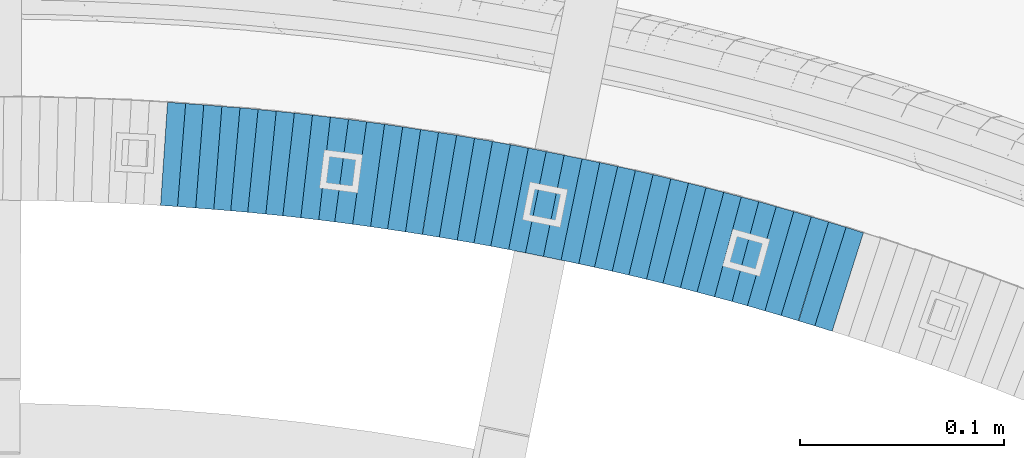
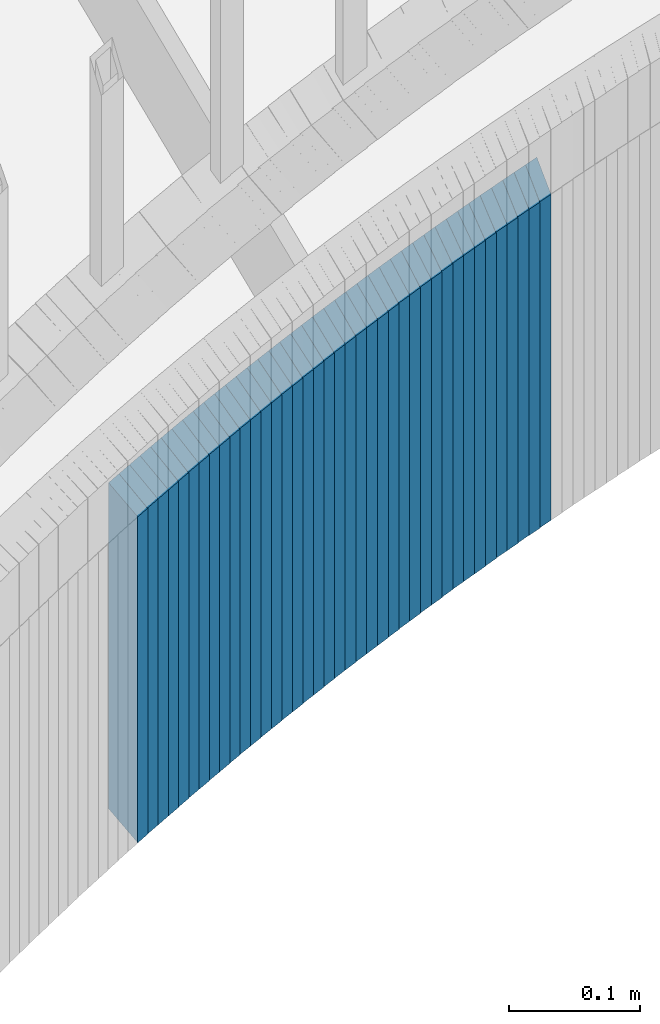
# One storey, part 901 of 975: 39 plates.
"""IFC2X3 building model written with IfcOpenShell, lengths in millimetres."""

from ifc_helpers import new_model, si_unit, frame, origin_with_axes, place, context, subcontext, project, spatial, faceted_brep, material, type_object, element, save


model = new_model("IFC2X3")

# Units and contexts
model_context = context("Model", 3, precision=1e-05, world=origin_with_axes())
body_context = subcontext(model_context, "Body", "Model", "MODEL_VIEW")
ifc_project = project(units=[si_unit("LENGTHUNIT", "METRE", prefix="MILLI"), si_unit("AREAUNIT", "SQUARE_METRE"), si_unit("VOLUMEUNIT", "CUBIC_METRE"), si_unit("MASSUNIT", "GRAM", prefix="KILO"), si_unit("TIMEUNIT", "SECOND"), si_unit("PLANEANGLEUNIT", "RADIAN"), si_unit("SOLIDANGLEUNIT", "STERADIAN"), si_unit("THERMODYNAMICTEMPERATUREUNIT", "DEGREE_CELSIUS"), si_unit("LUMINOUSINTENSITYUNIT", "LUMEN")], contexts=[model_context])

# Site, building, storey
site_placement = place(None, origin_with_axes())
site = spatial("IfcSite", under=ifc_project, at=site_placement, CompositionType="ELEMENT")
building_placement = place(site_placement, origin_with_axes())
building = spatial("IfcBuilding", under=site, at=building_placement, Name="Undefined", CompositionType="ELEMENT")
storey_placement = place(building_placement, origin_with_axes())
storey = spatial("IfcBuildingStorey", under=building, at=storey_placement, Name="Undefined", CompositionType="ELEMENT", Elevation=0.0)

# Plates
ifc_material = material(Name="STEEL/A36")
plate_type = type_object("IfcPlateType", PredefinedType="NOTDEFINED")
plate_1_placement = place(storey_placement, frame((35149.4859453928, 4737.7495007336, 1342.10000000059), z_axis=(0.953072925181811, -0.302740812057751, 0.0), x_axis=(0.0, 0.0, -1.0)))
element("IfcPlate", 1, at=plate_1_placement, inside=storey, type_object=plate_type, material=ifc_material, Name="WALL", context=body_context, shape_type="Brep", body=[
    faceted_brep([(0.0, -25.3999999999724, -1.81898940354586e-11), (-5.69999980926514, -25.3999999999724, 8.91964149478372), (-5.69999980926514, 25.400000000016, 8.9196414947528), (0.0, 25.3999999999869, 1.45519152283669e-11), (299.100006103516, -25.3999999999724, 8.91964149478372), (299.100006103516, 25.400000000016, 8.9196414947528), (304.799987792969, -25.3999999999724, -1.81898940354586e-11), (304.799987792969, 25.3999999999869, 1.45519152283669e-11)], [[[0, 1, 2, 3]], [[1, 4, 5, 2]], [[4, 6, 7, 5]], [[6, 0, 3, 7]], [[5, 7, 3, 2]], [[6, 4, 1, 0]]]),
])
plate_2_placement = place(storey_placement, frame((35141.2250686855, 4740.24438277839, 1336.40000000059), z_axis=(0.957211427350146, -0.289389501105857, 0.0), x_axis=(0.0, 0.0, -1.0)))
element("IfcPlate", 2, at=plate_2_placement, inside=storey, type_object=plate_type, material=ifc_material, Name="WALL", context=body_context, shape_type="Brep", body=[
    faceted_brep([(0.0, -25.3999999999724, -1.81898940354586e-11), (-5.69999980926514, -25.3999999999833, 8.98053455353147), (-5.69999980926514, 25.3999999999396, 8.98053455348781), (0.0, 25.3999999999869, 1.45519152283669e-11), (299.100006103516, -25.3999999999833, 8.98053455353147), (299.100006103516, 25.3999999999396, 8.98053455348781), (304.799987792969, -25.3999999999724, -1.81898940354586e-11), (304.799987792969, 25.3999999999869, 1.45519152283669e-11)], [[[0, 1, 2, 3]], [[1, 4, 5, 2]], [[4, 6, 7, 5]], [[6, 0, 3, 7]], [[5, 7, 3, 2]], [[6, 4, 1, 0]]]),
])
plate_3_placement = place(storey_placement, frame((35132.6459517336, 4742.86844248826, 1330.60000000059), z_axis=(0.956264194651992, -0.292504341893548, 0.0), x_axis=(0.0, 0.0, -1.0)))
element("IfcPlate", 3, at=plate_3_placement, inside=storey, type_object=plate_type, material=ifc_material, Name="WALL", context=body_context, shape_type="Brep", body=[
    faceted_brep([(0.0, -25.3999999999724, -1.81898940354586e-11), (-5.80000019073486, -25.3999999999542, 8.88650703432359), (-5.80000019073486, 25.4000000000233, 8.88650703432359), (0.0, 25.3999999999869, 1.45519152283669e-11), (299.0, -25.3999999999542, 8.88650703432359), (299.0, 25.4000000000233, 8.88650703432359), (304.799987792969, -25.3999999999724, -1.81898940354586e-11), (304.799987792969, 25.3999999999869, 1.45519152283669e-11)], [[[0, 1, 2, 3]], [[1, 4, 5, 2]], [[4, 6, 7, 5]], [[6, 0, 3, 7]], [[5, 7, 3, 2]], [[6, 4, 1, 0]]]),
])
for number, where, z_axis, x_axis, name in (
    (4, (35124.3853459953, 4745.26720992587, 1324.90000000059), (0.96024972858431, -0.279142362879158, 0.0), (0.0, 0.0, -1.0), "WALL"),
    (5, (35115.78534599, 4747.76720992593, 1319.20000000059), (0.96024972858431, -0.279142362879158, 0.0), (0.0, 0.0, -1.0), "WALL"),
):
    element("IfcPlate", number, at=place(storey_placement, frame(where, z_axis=z_axis, x_axis=x_axis)), inside=storey, type_object=plate_type, material=ifc_material, Name=name, context=body_context, shape_type="Brep", body=[
        faceted_brep([(0.0, -25.3999999999724, -1.81898940354586e-11), (-5.69999980926514, -25.4000000000087, 8.9643735885511), (-5.69999980926514, 25.4000000000669, 8.96437358860567), (0.0, 25.3999999999869, 1.45519152283669e-11), (299.100006103516, -25.4000000000087, 8.9643735885511), (299.100006103516, 25.4000000000669, 8.96437358860567), (304.799987792969, -25.3999999999724, -1.81898940354586e-11), (304.799987792969, 25.3999999999869, 1.45519152283669e-11)], [[[0, 1, 2, 3]], [[1, 4, 5, 2]], [[4, 6, 7, 5]], [[6, 0, 3, 7]], [[5, 7, 3, 2]], [[6, 4, 1, 0]]]),
    ])
plate_4_placement = place(storey_placement, frame((35107.4480682082, 4750.09236697988, 1313.40000000059), z_axis=(0.963196301261052, -0.268798968072851, 0.0), x_axis=(0.0, 0.0, -1.0)))
element("IfcPlate", 6, at=plate_4_placement, inside=storey, type_object=plate_type, material=ifc_material, Name="WALL", context=body_context, shape_type="Brep", body=[
    faceted_brep([(0.0, -25.3999999999724, -1.81898940354586e-11), (-5.80000019073486, -25.399999999976, 8.9274854660398), (-5.80000019073486, 25.4000000000269, 8.92748546601433), (0.0, 25.3999999999869, 1.45519152283669e-11), (299.0, -25.399999999976, 8.9274854660398), (299.0, 25.4000000000269, 8.92748546601433), (304.799987792969, -25.3999999999724, -1.81898940354586e-11), (304.799987792969, 25.3999999999869, 1.45519152283669e-11)], [[[0, 1, 2, 3]], [[1, 4, 5, 2]], [[4, 6, 7, 5]], [[6, 0, 3, 7]], [[5, 7, 3, 2]], [[6, 4, 1, 0]]]),
])
for number, where, z_axis, x_axis, name in (
    (7, (35099.113173802, 4752.31992761313, 1307.70000000059), (0.966048244824465, -0.258361739953056, 0.0), (0.0, 0.0, -1.0), "WALL"),
    (8, (35090.5131737926, 4754.6199276129, 1302.00000000058), (0.966048244824465, -0.258361739953056, 0.0), (0.0, 0.0, -1.0), "WALL"),
):
    element("IfcPlate", number, at=place(storey_placement, frame(where, z_axis=z_axis, x_axis=x_axis)), inside=storey, type_object=plate_type, material=ifc_material, Name=name, context=body_context, shape_type="Brep", body=[
        faceted_brep([(0.0, -25.3999999999724, -1.81898940354586e-11), (-5.69999980926514, -25.3999999999724, 8.90224647524519), (-5.69999980926514, 25.3999999999542, 8.90224647519426), (0.0, 25.3999999999869, 1.45519152283669e-11), (299.100006103516, -25.3999999999724, 8.90224647524519), (299.100006103516, 25.3999999999542, 8.90224647519426), (304.799987792969, -25.3999999999724, -1.81898940354586e-11), (304.799987792969, 25.3999999999869, 1.45519152283669e-11)], [[[0, 1, 2, 3]], [[1, 4, 5, 2]], [[4, 6, 7, 5]], [[6, 0, 3, 7]], [[5, 7, 3, 2]], [[6, 4, 1, 0]]]),
    ])
plate_5_placement = place(storey_placement, frame((35081.8836493653, 4756.90118785796, 1296.30000000058), z_axis=(0.966786030429018, -0.255587111113418, 0.0), x_axis=(0.0, 0.0, -1.0)))
element("IfcPlate", 9, at=plate_5_placement, inside=storey, type_object=plate_type, material=ifc_material, Name="WALL", context=body_context, shape_type="Brep", body=[
    faceted_brep([(0.0, -25.3999999999724, -1.81898940354586e-11), (-5.69999980926514, -25.3999999999724, 9.00000000009459), (-5.69999980926514, 25.3999999999905, 8.99999999997453), (0.0, 25.3999999999869, 1.45519152283669e-11), (299.100006103516, -25.3999999999724, 9.00000000009459), (299.100006103516, 25.3999999999905, 8.99999999997453), (304.799987792969, -25.3999999999724, -1.81898940354586e-11), (304.799987792969, 25.3999999999869, 1.45519152283669e-11)], [[[0, 1, 2, 3]], [[1, 4, 5, 2]], [[4, 6, 7, 5]], [[6, 0, 3, 7]], [[5, 7, 3, 2]], [[6, 4, 1, 0]]]),
])
plate_6_placement = place(storey_placement, frame((35073.4805974367, 4759.04996433797, 1290.50000000059), z_axis=(0.968802704444063, -0.247833250113597, 0.0), x_axis=(0.0, 0.0, -1.0)))
element("IfcPlate", 10, at=plate_6_placement, inside=storey, type_object=plate_type, material=ifc_material, Name="WALL", context=body_context, shape_type="Brep", body=[
    faceted_brep([(0.0, -25.3999999999724, -1.81898940354586e-11), (-5.80000019073486, -25.4000000000015, 8.88144111634028), (-5.80000019073486, 25.4000000000269, 8.88144111639849), (0.0, 25.3999999999869, 1.45519152283669e-11), (299.0, -25.4000000000015, 8.88144111634028), (299.0, 25.4000000000269, 8.88144111639849), (304.799987792969, -25.3999999999724, -1.81898940354586e-11), (304.799987792969, 25.3999999999869, 1.45519152283669e-11)], [[[0, 1, 2, 3]], [[1, 4, 5, 2]], [[4, 6, 7, 5]], [[6, 0, 3, 7]], [[5, 7, 3, 2]], [[6, 4, 1, 0]]]),
])
for number, where, z_axis, x_axis, name in (
    (11, (35065.1156924511, 4761.06666493178, 1284.80000000059), (0.972082208620478, -0.234640532908391, 0.0), (0.0, 0.0, -1.0), "WALL"),
    (12, (35056.4156924486, 4763.16666493143, 1279.10000000058), (0.972082208620478, -0.234640532908391, 0.0), (0.0, 0.0, -1.0), "WALL"),
):
    element("IfcPlate", number, at=place(storey_placement, frame(where, z_axis=z_axis, x_axis=x_axis)), inside=storey, type_object=plate_type, material=ifc_material, Name=name, context=body_context, shape_type="Brep", body=[
        faceted_brep([(0.0, -25.3999999999724, -1.81898940354586e-11), (-5.69999980926514, -25.4000000000451, 8.94986057279493), (-5.69999980926514, 25.3999999999942, 8.94986057280948), (0.0, 25.3999999999869, 1.45519152283669e-11), (299.100006103516, -25.4000000000451, 8.94986057279493), (299.100006103516, 25.3999999999942, 8.94986057280948), (304.799987792969, -25.3999999999724, -1.81898940354586e-11), (304.799987792969, 25.3999999999869, 1.45519152283669e-11)], [[[0, 1, 2, 3]], [[1, 4, 5, 2]], [[4, 6, 7, 5]], [[6, 0, 3, 7]], [[5, 7, 3, 2]], [[6, 4, 1, 0]]]),
    ])
plate_7_placement = place(storey_placement, frame((35047.9849129868, 4765.10322989238, 1273.30000000058), z_axis=(0.974579651097025, -0.224041299022305, 0.0), x_axis=(0.0, 0.0, -1.0)))
element("IfcPlate", 13, at=plate_7_placement, inside=storey, type_object=plate_type, material=ifc_material, Name="WALL", context=body_context, shape_type="Brep", body=[
    faceted_brep([(0.0, -25.3999999999724, -1.81898940354586e-11), (-5.80000019073486, -25.399999999976, 8.9274854660398), (-5.80000019073486, 25.4000000000269, 8.92748546601433), (0.0, 25.3999999999869, 1.45519152283669e-11), (299.0, -25.399999999976, 8.9274854660398), (299.0, 25.4000000000269, 8.92748546601433), (304.799987792969, -25.3999999999724, -1.81898940354586e-11), (304.799987792969, 25.3999999999869, 1.45519152283669e-11)], [[[0, 1, 2, 3]], [[1, 4, 5, 2]], [[4, 6, 7, 5]], [[6, 0, 3, 7]], [[5, 7, 3, 2]], [[6, 4, 1, 0]]]),
])
plate_8_placement = place(storey_placement, frame((35039.2849129928, 4767.10322989223, 1267.60000000058), z_axis=(0.974579651097025, -0.224041299022305, 0.0), x_axis=(0.0, 0.0, -1.0)))
element("IfcPlate", 14, at=plate_8_placement, inside=storey, type_object=plate_type, material=ifc_material, Name="WALL", context=body_context, shape_type="Brep", body=[
    faceted_brep([(0.0, -25.3999999999724, -1.81898940354586e-11), (-5.69999980926514, -25.3999999999141, 8.92748546604707), (-5.69999980926514, 25.3999999999505, 8.92748546598159), (0.0, 25.3999999999869, 1.45519152283669e-11), (299.100006103516, -25.3999999999141, 8.92748546604707), (299.100006103516, 25.3999999999505, 8.92748546598159), (304.799987792969, -25.3999999999724, -1.81898940354586e-11), (304.799987792969, 25.3999999999869, 1.45519152283669e-11)], [[[0, 1, 2, 3]], [[1, 4, 5, 2]], [[4, 6, 7, 5]], [[6, 0, 3, 7]], [[5, 7, 3, 2]], [[6, 4, 1, 0]]]),
])
plate_9_placement = place(storey_placement, frame((35030.8149939878, 4768.92965922533, 1261.80000000058), z_axis=(0.97747613404784, -0.21104598401033, 0.0), x_axis=(0.0, 0.0, -1.0)))
element("IfcPlate", 15, at=plate_9_placement, inside=storey, type_object=plate_type, material=ifc_material, Name="WALL", context=body_context, shape_type="Brep", body=[
    faceted_brep([(0.0, -25.3999999999724, -1.81898940354586e-11), (-5.80000019073486, -25.3999999999578, 8.99610996247975), (-5.80000019073486, 25.3999999999796, 8.99610996245065), (0.0, 25.3999999999869, 1.45519152283669e-11), (299.0, -25.3999999999578, 8.99610996247975), (299.0, 25.3999999999796, 8.99610996245065), (304.799987792969, -25.3999999999724, -1.81898940354586e-11), (304.799987792969, 25.3999999999869, 1.45519152283669e-11)], [[[0, 1, 2, 3]], [[1, 4, 5, 2]], [[4, 6, 7, 5]], [[6, 0, 3, 7]], [[5, 7, 3, 2]], [[6, 4, 1, 0]]]),
])
plate_10_placement = place(storey_placement, frame((35022.3293796421, 4770.68433837385, 1256.10000000059), z_axis=(0.979260419534469, -0.202605603903684, 0.0), x_axis=(0.0, 0.0, -1.0)))
element("IfcPlate", 16, at=plate_10_placement, inside=storey, type_object=plate_type, material=ifc_material, Name="WALL", context=body_context, shape_type="Brep", body=[
    faceted_brep([(0.0, -25.3999999999724, -1.81898940354586e-11), (-5.69999980926514, -25.4000000000669, 8.8814411163039), (-5.69999980926514, 25.400000000096, 8.88144111637848), (0.0, 25.3999999999869, 1.45519152283669e-11), (299.100006103516, -25.4000000000669, 8.8814411163039), (299.100006103516, 25.400000000096, 8.88144111637848), (304.799987792969, -25.3999999999724, -1.81898940354586e-11), (304.799987792969, 25.3999999999869, 1.45519152283669e-11)], [[[0, 1, 2, 3]], [[1, 4, 5, 2]], [[4, 6, 7, 5]], [[6, 0, 3, 7]], [[5, 7, 3, 2]], [[6, 4, 1, 0]]]),
])
plate_11_placement = place(storey_placement, frame((35013.585497585, 4772.47279374954, 1250.30000000058), z_axis=(0.979714932300414, -0.200396236061448, 0.0), x_axis=(0.0, 0.0, -1.0)))
element("IfcPlate", 17, at=plate_11_placement, inside=storey, type_object=plate_type, material=ifc_material, Name="WALL", context=body_context, shape_type="Brep", body=[
    faceted_brep([(0.0, -25.3999999999724, -1.81898940354586e-11), (-5.80000019073486, -25.3999999999542, 8.98276138308574), (-5.80000019073486, 25.3999999999469, 8.98276138302026), (0.0, 25.3999999999869, 1.45519152283669e-11), (299.0, -25.3999999999542, 8.98276138308574), (299.0, 25.3999999999469, 8.98276138302026), (304.799987792969, -25.3999999999724, -1.81898940354586e-11), (304.799987792969, 25.3999999999869, 1.45519152283669e-11)], [[[0, 1, 2, 3]], [[1, 4, 5, 2]], [[4, 6, 7, 5]], [[6, 0, 3, 7]], [[5, 7, 3, 2]], [[6, 4, 1, 0]]]),
])
plate_12_placement = place(storey_placement, frame((35004.7854975847, 4774.27279374947, 1244.60000000058), z_axis=(0.979714932300414, -0.200396236061448, 0.0), x_axis=(0.0, 0.0, -1.0)))
element("IfcPlate", 18, at=plate_12_placement, inside=storey, type_object=plate_type, material=ifc_material, Name="WALL", context=body_context, shape_type="Brep", body=[
    faceted_brep([(0.0, -25.3999999999724, -1.81898940354586e-11), (-5.69999980926514, -25.3999999999833, 8.98053455353147), (-5.69999980926514, 25.3999999999396, 8.98053455348781), (0.0, 25.3999999999869, 1.45519152283669e-11), (299.100006103516, -25.3999999999833, 8.98053455353147), (299.100006103516, 25.3999999999396, 8.98053455348781), (304.799987792969, -25.3999999999724, -1.81898940354586e-11), (304.799987792969, 25.3999999999869, 1.45519152283669e-11)], [[[0, 1, 2, 3]], [[1, 4, 5, 2]], [[4, 6, 7, 5]], [[6, 0, 3, 7]], [[5, 7, 3, 2]], [[6, 4, 1, 0]]]),
])
plate_13_placement = place(storey_placement, frame((34996.2578175934, 4775.91864088435, 1238.90000000058), z_axis=(0.98184693485788, -0.189674975972545, 0.0), x_axis=(0.0, 0.0, -1.0)))
element("IfcPlate", 19, at=plate_13_placement, inside=storey, type_object=plate_type, material=ifc_material, Name="WALL", context=body_context, shape_type="Brep", body=[
    faceted_brep([(0.0, -25.3999999999724, -1.81898940354586e-11), (-5.69999980926514, -25.4000000000087, 8.9643735885511), (-5.69999980926514, 25.4000000000669, 8.96437358860567), (0.0, 25.3999999999869, 1.45519152283669e-11), (299.100006103516, -25.4000000000087, 8.9643735885511), (299.100006103516, 25.4000000000669, 8.96437358860567), (304.799987792969, -25.3999999999724, -1.81898940354586e-11), (304.799987792969, 25.3999999999869, 1.45519152283669e-11)], [[[0, 1, 2, 3]], [[1, 4, 5, 2]], [[4, 6, 7, 5]], [[6, 0, 3, 7]], [[5, 7, 3, 2]], [[6, 4, 1, 0]]]),
])
plate_14_placement = place(storey_placement, frame((34987.4578175959, 4777.6186408842, 1233.10000000058), z_axis=(0.98184693485788, -0.189674975972545, 0.0), x_axis=(0.0, 0.0, -1.0)))
element("IfcPlate", 20, at=plate_14_placement, inside=storey, type_object=plate_type, material=ifc_material, Name="WALL", context=body_context, shape_type="Brep", body=[
    faceted_brep([(0.0, -25.3999999999724, -1.81898940354586e-11), (-5.80000019073486, -25.3999999999396, 8.9627008438656), (-5.80000019073486, 25.3999999999178, 8.96270084374191), (0.0, 25.3999999999869, 1.45519152283669e-11), (299.0, -25.3999999999396, 8.9627008438656), (299.0, 25.3999999999178, 8.96270084374191), (304.799987792969, -25.3999999999724, -1.81898940354586e-11), (304.799987792969, 25.3999999999869, 1.45519152283669e-11)], [[[0, 1, 2, 3]], [[1, 4, 5, 2]], [[4, 6, 7, 5]], [[6, 0, 3, 7]], [[5, 7, 3, 2]], [[6, 4, 1, 0]]]),
])
plate_15_placement = place(storey_placement, frame((34978.9318718559, 4779.16725731242, 1227.40000000058), z_axis=(0.983869910131907, -0.178885438023984, 0.0), x_axis=(0.0, 0.0, -1.0)))
element("IfcPlate", 21, at=plate_15_placement, inside=storey, type_object=plate_type, material=ifc_material, Name="WALL", context=body_context, shape_type="Brep", body=[
    faceted_brep([(0.0, -25.3999999999724, -1.81898940354586e-11), (-5.69999980926514, -25.4000000000415, 8.93756103511259), (-5.69999980926514, 25.4000000000815, 8.93756103522537), (0.0, 25.3999999999869, 1.45519152283669e-11), (299.100006103516, -25.4000000000415, 8.93756103511259), (299.100006103516, 25.4000000000815, 8.93756103522537), (304.799987792969, -25.3999999999724, -1.81898940354586e-11), (304.799987792969, 25.3999999999869, 1.45519152283669e-11)], [[[0, 1, 2, 3]], [[1, 4, 5, 2]], [[4, 6, 7, 5]], [[6, 0, 3, 7]], [[5, 7, 3, 2]], [[6, 4, 1, 0]]]),
])
plate_16_placement = place(storey_placement, frame((34970.4075752441, 4780.61869744155, 1221.60000000058), z_axis=(0.985781716087097, -0.168030974014847, 0.0), x_axis=(0.0, 0.0, -1.0)))
element("IfcPlate", 22, at=plate_16_placement, inside=storey, type_object=plate_type, material=ifc_material, Name="WALL", context=body_context, shape_type="Brep", body=[
    faceted_brep([(0.0, -25.3999999999724, -1.81898940354586e-11), (-5.80000019073486, -25.399999999976, 8.9274854660398), (-5.80000019073486, 25.4000000000269, 8.92748546601433), (0.0, 25.3999999999869, 1.45519152283669e-11), (299.0, -25.399999999976, 8.9274854660398), (299.0, 25.4000000000269, 8.92748546601433), (304.799987792969, -25.3999999999724, -1.81898940354586e-11), (304.799987792969, 25.3999999999869, 1.45519152283669e-11)], [[[0, 1, 2, 3]], [[1, 4, 5, 2]], [[4, 6, 7, 5]], [[6, 0, 3, 7]], [[5, 7, 3, 2]], [[6, 4, 1, 0]]]),
])
plate_17_placement = place(storey_placement, frame((34961.6075752465, 4782.11869744193, 1215.90000000058), z_axis=(0.985781716087097, -0.168030974014847, 0.0), x_axis=(0.0, 0.0, -1.0)))
element("IfcPlate", 23, at=plate_17_placement, inside=storey, type_object=plate_type, material=ifc_material, Name="WALL", context=body_context, shape_type="Brep", body=[
    faceted_brep([(0.0, -25.3999999999724, -1.81898940354586e-11), (-5.69999980926514, -25.3999999999141, 8.92748546604707), (-5.69999980926514, 25.3999999999505, 8.92748546598159), (0.0, 25.3999999999869, 1.45519152283669e-11), (299.100006103516, -25.3999999999141, 8.92748546604707), (299.100006103516, 25.3999999999505, 8.92748546598159), (304.799987792969, -25.3999999999724, -1.81898940354586e-11), (304.799987792969, 25.3999999999869, 1.45519152283669e-11)], [[[0, 1, 2, 3]], [[1, 4, 5, 2]], [[4, 6, 7, 5]], [[6, 0, 3, 7]], [[5, 7, 3, 2]], [[6, 4, 1, 0]]]),
])
plate_18_placement = place(storey_placement, frame((34953.0285905854, 4783.46609199755, 1210.10000000057), z_axis=(0.987852796552575, -0.155392574929619, 0.0), x_axis=(0.0, 0.0, -1.0)))
element("IfcPlate", 24, at=plate_18_placement, inside=storey, type_object=plate_type, material=ifc_material, Name="WALL", context=body_context, shape_type="Brep", body=[
    faceted_brep([(0.0, -25.3999999999724, -1.81898940354586e-11), (-5.80000019073486, -25.4000000000106, 9.00943946835469), (-5.80000019073486, 25.4000000000269, 9.00943946848565), (0.0, 25.3999999999869, 1.45519152283669e-11), (299.0, -25.4000000000106, 9.00943946835469), (299.0, 25.4000000000269, 9.00943946848565), (304.799987792969, -25.3999999999724, -1.81898940354586e-11), (304.799987792969, 25.3999999999869, 1.45519152283669e-11)], [[[0, 1, 2, 3]], [[1, 4, 5, 2]], [[4, 6, 7, 5]], [[6, 0, 3, 7]], [[5, 7, 3, 2]], [[6, 4, 1, 0]]]),
])
plate_19_placement = place(storey_placement, frame((34944.1848397397, 4784.87301325078, 1204.40000000057), z_axis=(0.987580306285744, -0.157115049045458, 0.0), x_axis=(0.0, 0.0, -1.0)))
element("IfcPlate", 25, at=plate_19_placement, inside=storey, type_object=plate_type, material=ifc_material, Name="WALL", context=body_context, shape_type="Brep", body=[
    faceted_brep([(0.0, -25.3999999999724, -1.81898940354586e-11), (-5.69999980926514, -25.400000000096, 8.9140338897214), (-5.69999980926514, 25.4000000000524, 8.91403388979779), (0.0, 25.3999999999869, 1.45519152283669e-11), (299.100006103516, -25.400000000096, 8.9140338897214), (299.100006103516, 25.4000000000524, 8.91403388979779), (304.799987792969, -25.3999999999724, -1.81898940354586e-11), (304.799987792969, 25.3999999999869, 1.45519152283669e-11)], [[[0, 1, 2, 3]], [[1, 4, 5, 2]], [[4, 6, 7, 5]], [[6, 0, 3, 7]], [[5, 7, 3, 2]], [[6, 4, 1, 0]]]),
])
plate_20_placement = place(storey_placement, frame((34935.6635746441, 4786.13025413153, 1198.70000000057), z_axis=(0.989263736178206, -0.146141234026325, 0.0), x_axis=(0.0, 0.0, -1.0)))
element("IfcPlate", 26, at=plate_20_placement, inside=storey, type_object=plate_type, material=ifc_material, Name="WALL", context=body_context, shape_type="Brep", body=[
    faceted_brep([(0.0, -25.3999999999724, -1.81898940354586e-11), (-5.69999980926514, -25.3999999999724, 8.90224647524519), (-5.69999980926514, 25.3999999999542, 8.90224647519426), (0.0, 25.3999999999869, 1.45519152283669e-11), (299.100006103516, -25.3999999999724, 8.90224647524519), (299.100006103516, 25.3999999999542, 8.90224647519426), (304.799987792969, -25.3999999999724, -1.81898940354586e-11), (304.799987792969, 25.3999999999869, 1.45519152283669e-11)], [[[0, 1, 2, 3]], [[1, 4, 5, 2]], [[4, 6, 7, 5]], [[6, 0, 3, 7]], [[5, 7, 3, 2]], [[6, 4, 1, 0]]]),
])
plate_21_placement = place(storey_placement, frame((34926.8044062569, 4787.42425607926, 1192.90000000057), z_axis=(0.989499879967826, -0.1445336899953, 0.0), x_axis=(0.0, 0.0, -1.0)))
element("IfcPlate", 27, at=plate_21_placement, inside=storey, type_object=plate_type, material=ifc_material, Name="WALL", context=body_context, shape_type="Brep", body=[
    faceted_brep([(0.0, -25.3999999999724, -1.81898940354586e-11), (-5.80000019073486, -25.3999999999796, 8.98721313478018), (-5.80000019073486, 25.399999999936, 8.98721313473106), (0.0, 25.3999999999869, 1.45519152283669e-11), (299.0, -25.3999999999796, 8.98721313478018), (299.0, 25.399999999936, 8.98721313473106), (304.799987792969, -25.3999999999724, -1.81898940354586e-11), (304.799987792969, 25.3999999999869, 1.45519152283669e-11)], [[[0, 1, 2, 3]], [[1, 4, 5, 2]], [[4, 6, 7, 5]], [[6, 0, 3, 7]], [[5, 7, 3, 2]], [[6, 4, 1, 0]]]),
])
plate_22_placement = place(storey_placement, frame((34918.2436865732, 4788.59046676339, 1187.20000000057), z_axis=(0.990830168007788, -0.135113205001062, 0.0), x_axis=(0.0, 0.0, -1.0)))
element("IfcPlate", 28, at=plate_22_placement, inside=storey, type_object=plate_type, material=ifc_material, Name="WALL", context=body_context, shape_type="Brep", body=[
    faceted_brep([(0.0, -25.3999999999724, -1.81898940354586e-11), (-5.69999980926514, -25.4000000000669, 8.8814411163039), (-5.69999980926514, 25.400000000096, 8.88144111637848), (0.0, 25.3999999999869, 1.45519152283669e-11), (299.100006103516, -25.4000000000669, 8.8814411163039), (299.100006103516, 25.400000000096, 8.88144111637848), (304.799987792969, -25.3999999999724, -1.81898940354586e-11), (304.799987792969, 25.3999999999869, 1.45519152283669e-11)], [[[0, 1, 2, 3]], [[1, 4, 5, 2]], [[4, 6, 7, 5]], [[6, 0, 3, 7]], [[5, 7, 3, 2]], [[6, 4, 1, 0]]]),
])
plate_23_placement = place(storey_placement, frame((34909.3815546422, 4789.78533194806, 1181.50000000056), z_axis=(0.991032326071816, -0.133622336009684, 0.0), x_axis=(0.0, 0.0, -1.0)))
element("IfcPlate", 29, at=plate_23_placement, inside=storey, type_object=plate_type, material=ifc_material, Name="WALL", context=body_context, shape_type="Brep", body=[
    faceted_brep([(0.0, -25.3999999999724, -1.81898940354586e-11), (-5.69999980926514, -25.3999999999833, 8.98053455353147), (-5.69999980926514, 25.3999999999396, 8.98053455348781), (0.0, 25.3999999999869, 1.45519152283669e-11), (299.100006103516, -25.3999999999833, 8.98053455353147), (299.100006103516, 25.3999999999396, 8.98053455348781), (304.799987792969, -25.3999999999724, -1.81898940354586e-11), (304.799987792969, 25.3999999999869, 1.45519152283669e-11)], [[[0, 1, 2, 3]], [[1, 4, 5, 2]], [[4, 6, 7, 5]], [[6, 0, 3, 7]], [[5, 7, 3, 2]], [[6, 4, 1, 0]]]),
])
plate_24_placement = place(storey_placement, frame((34900.7599428077, 4790.84936156034, 1175.80000000056), z_axis=(0.99244848307505, -0.122662172009276, 0.0), x_axis=(0.0, 0.0, -1.0)))
element("IfcPlate", 30, at=plate_24_placement, inside=storey, type_object=plate_type, material=ifc_material, Name="WALL", context=body_context, shape_type="Brep", body=[
    faceted_brep([(0.0, -25.3999999999724, -1.81898940354586e-11), (-5.69999980926514, -25.4000000000669, 8.96939277644015), (-5.69999980926514, 25.4000000000524, 8.96939277652928), (0.0, 25.3999999999869, 1.45519152283669e-11), (299.100006103516, -25.4000000000669, 8.96939277644015), (299.100006103516, 25.4000000000524, 8.96939277652928), (304.799987792969, -25.3999999999724, -1.81898940354586e-11), (304.799987792969, 25.3999999999869, 1.45519152283669e-11)], [[[0, 1, 2, 3]], [[1, 4, 5, 2]], [[4, 6, 7, 5]], [[6, 0, 3, 7]], [[5, 7, 3, 2]], [[6, 4, 1, 0]]]),
])
plate_25_placement = place(storey_placement, frame((34892.2076559002, 4791.81997955832, 1170.00000000056), z_axis=(0.993605254797368, -0.112909687976973, 0.0), x_axis=(0.0, 0.0, -1.0)))
element("IfcPlate", 31, at=plate_25_placement, inside=storey, type_object=plate_type, material=ifc_material, Name="WALL", context=body_context, shape_type="Brep", body=[
    faceted_brep([(0.0, -25.3999999999724, -1.81898940354586e-11), (-5.80000019073486, -25.3999999999905, 8.8617153167761), (-5.80000019073486, 25.4000000000524, 8.86171531681975), (0.0, 25.3999999999869, 1.45519152283669e-11), (299.0, -25.3999999999905, 8.8617153167761), (299.0, 25.4000000000524, 8.86171531681975), (304.799987792969, -25.3999999999724, -1.81898940354586e-11), (304.799987792969, 25.3999999999869, 1.45519152283669e-11)], [[[0, 1, 2, 3]], [[1, 4, 5, 2]], [[4, 6, 7, 5]], [[6, 0, 3, 7]], [[5, 7, 3, 2]], [[6, 4, 1, 0]]]),
])
plate_26_placement = place(storey_placement, frame((34883.3394755705, 4792.81638400135, 1164.30000000055), z_axis=(0.993746812135698, -0.111656945015246, 0.0), x_axis=(0.0, 0.0, -1.0)))
element("IfcPlate", 32, at=plate_26_placement, inside=storey, type_object=plate_type, material=ifc_material, Name="WALL", context=body_context, shape_type="Brep", body=[
    faceted_brep([(0.0, -25.3999999999724, -1.81898940354586e-11), (-5.69999980926514, -25.4000000000087, 8.9643735885511), (-5.69999980926514, 25.4000000000669, 8.96437358860567), (0.0, 25.3999999999869, 1.45519152283669e-11), (299.100006103516, -25.4000000000087, 8.9643735885511), (299.100006103516, 25.4000000000669, 8.96437358860567), (304.799987792969, -25.3999999999724, -1.81898940354586e-11), (304.799987792969, 25.3999999999869, 1.45519152283669e-11)], [[[0, 1, 2, 3]], [[1, 4, 5, 2]], [[4, 6, 7, 5]], [[6, 0, 3, 7]], [[5, 7, 3, 2]], [[6, 4, 1, 0]]]),
])
plate_27_placement = place(storey_placement, frame((34874.7200557029, 4793.68643537106, 1158.60000000055), z_axis=(0.994925892068904, -0.100610483006968, 0.0), x_axis=(0.0, 0.0, -1.0)))
element("IfcPlate", 33, at=plate_27_placement, inside=storey, type_object=plate_type, material=ifc_material, Name="WALL", context=body_context, shape_type="Brep", body=[
    faceted_brep([(0.0, -25.3999999999724, -1.81898940354586e-11), (-5.69999980926514, -25.4000000000451, 8.94986057279493), (-5.69999980926514, 25.3999999999942, 8.94986057280948), (0.0, 25.3999999999869, 1.45519152283669e-11), (299.100006103516, -25.4000000000451, 8.94986057279493), (299.100006103516, 25.3999999999942, 8.94986057280948), (304.799987792969, -25.3999999999724, -1.81898940354586e-11), (304.799987792969, 25.3999999999869, 1.45519152283669e-11)], [[[0, 1, 2, 3]], [[1, 4, 5, 2]], [[4, 6, 7, 5]], [[6, 0, 3, 7]], [[5, 7, 3, 2]], [[6, 4, 1, 0]]]),
])
plate_28_placement = place(storey_placement, frame((34865.8200557004, 4794.58643537105, 1152.80000000055), z_axis=(0.994925892068904, -0.100610483006968, 0.0), x_axis=(0.0, 0.0, -1.0)))
element("IfcPlate", 34, at=plate_28_placement, inside=storey, type_object=plate_type, material=ifc_material, Name="WALL", context=body_context, shape_type="Brep", body=[
    faceted_brep([(0.0, -25.3999999999724, -1.81898940354586e-11), (-5.80000019073486, -25.4000000000742, 8.94706630702785), (-5.80000019073486, 25.4000000000306, 8.9470663070897), (0.0, 25.3999999999869, 1.45519152283669e-11), (299.0, -25.4000000000742, 8.94706630702785), (299.0, 25.4000000000306, 8.9470663070897), (304.799987792969, -25.3999999999724, -1.81898940354586e-11), (304.799987792969, 25.3999999999869, 1.45519152283669e-11)], [[[0, 1, 2, 3]], [[1, 4, 5, 2]], [[4, 6, 7, 5]], [[6, 0, 3, 7]], [[5, 7, 3, 2]], [[6, 4, 1, 0]]]),
])
plate_29_placement = place(storey_placement, frame((34857.201584039, 4795.35954867351, 1147.10000000054), z_axis=(0.995984423457655, -0.0895266900411373, 0.0), x_axis=(0.0, 0.0, -1.0)))
element("IfcPlate", 35, at=plate_29_placement, inside=storey, type_object=plate_type, material=ifc_material, Name="WALL", context=body_context, shape_type="Brep", body=[
    faceted_brep([(0.0, -25.3999999999724, -1.81898940354586e-11), (-5.69999980926514, -25.4000000000415, 8.93756103511259), (-5.69999980926514, 25.4000000000815, 8.93756103522537), (0.0, 25.3999999999869, 1.45519152283669e-11), (299.100006103516, -25.4000000000415, 8.93756103511259), (299.100006103516, 25.4000000000815, 8.93756103522537), (304.799987792969, -25.3999999999724, -1.81898940354586e-11), (304.799987792969, 25.3999999999869, 1.45519152283669e-11)], [[[0, 1, 2, 3]], [[1, 4, 5, 2]], [[4, 6, 7, 5]], [[6, 0, 3, 7]], [[5, 7, 3, 2]], [[6, 4, 1, 0]]]),
])
plate_30_placement = place(storey_placement, frame((34848.5839597781, 4796.03575371118, 1141.40000000055), z_axis=(0.996921233007399, -0.0784095350005817, 0.0), x_axis=(0.0, 0.0, -1.0)))
element("IfcPlate", 36, at=plate_30_placement, inside=storey, type_object=plate_type, material=ifc_material, Name="WALL", context=body_context, shape_type="Brep", body=[
    faceted_brep([(0.0, -25.3999999999724, -1.81898940354586e-11), (-5.69999980926514, -25.3999999999141, 8.92748546604707), (-5.69999980926514, 25.3999999999505, 8.92748546598159), (0.0, 25.3999999999869, 1.45519152283669e-11), (299.100006103516, -25.3999999999141, 8.92748546604707), (299.100006103516, 25.3999999999505, 8.92748546598159), (304.799987792969, -25.3999999999724, -1.81898940354586e-11), (304.799987792969, 25.3999999999869, 1.45519152283669e-11)], [[[0, 1, 2, 3]], [[1, 4, 5, 2]], [[4, 6, 7, 5]], [[6, 0, 3, 7]], [[5, 7, 3, 2]], [[6, 4, 1, 0]]]),
])
plate_31_placement = place(storey_placement, frame((34839.6839597791, 4796.73575371139, 1135.60000000055), z_axis=(0.996921233007399, -0.0784095350005817, 0.0), x_axis=(0.0, 0.0, -1.0)))
element("IfcPlate", 37, at=plate_31_placement, inside=storey, type_object=plate_type, material=ifc_material, Name="WALL", context=body_context, shape_type="Brep", body=[
    faceted_brep([(0.0, -25.3999999999724, -1.81898940354586e-11), (-5.80000019073486, -25.399999999976, 8.9274854660398), (-5.80000019073486, 25.4000000000269, 8.92748546601433), (0.0, 25.3999999999869, 1.45519152283669e-11), (299.0, -25.399999999976, 8.9274854660398), (299.0, 25.4000000000269, 8.92748546601433), (304.799987792969, -25.3999999999724, -1.81898940354586e-11), (304.799987792969, 25.3999999999869, 1.45519152283669e-11)], [[[0, 1, 2, 3]], [[1, 4, 5, 2]], [[4, 6, 7, 5]], [[6, 0, 3, 7]], [[5, 7, 3, 2]], [[6, 4, 1, 0]]]),
])
plate_32_placement = place(storey_placement, frame((34830.7839597802, 4797.43575371161, 1129.90000000055), z_axis=(0.996921233007399, -0.0784095350005817, 0.0), x_axis=(0.0, 0.0, -1.0)))
element("IfcPlate", 38, at=plate_32_placement, inside=storey, type_object=plate_type, material=ifc_material, Name="WALL", context=body_context, shape_type="Brep", body=[
    faceted_brep([(0.0, -25.3999999999724, -1.81898940354586e-11), (-5.69999980926514, -25.3999999999141, 8.92748546604707), (-5.69999980926514, 25.3999999999505, 8.92748546598159), (0.0, 25.3999999999869, 1.45519152283669e-11), (299.100006103516, -25.3999999999141, 8.92748546604707), (299.100006103516, 25.3999999999505, 8.92748546598159), (304.799987792969, -25.3999999999724, -1.81898940354586e-11), (304.799987792969, 25.3999999999869, 1.45519152283669e-11)], [[[0, 1, 2, 3]], [[1, 4, 5, 2]], [[4, 6, 7, 5]], [[6, 0, 3, 7]], [[5, 7, 3, 2]], [[6, 4, 1, 0]]]),
])
plate_33_placement = place(storey_placement, frame((34822.1670804487, 4798.01507700847, 1124.20000000056), z_axis=(0.99773527642945, -0.0672630520289523, 0.0), x_axis=(0.0, 0.0, -1.0)))
element("IfcPlate", 39, at=plate_33_placement, inside=storey, type_object=plate_type, material=ifc_material, Name="WALL", context=body_context, shape_type="Brep", body=[
    faceted_brep([(0.0, -25.3999999999724, -1.81898940354586e-11), (-5.69999980926514, -25.3999999999724, 8.91964149478372), (-5.69999980926514, 25.400000000016, 8.9196414947528), (0.0, 25.3999999999869, 1.45519152283669e-11), (299.100006103516, -25.3999999999724, 8.91964149478372), (299.100006103516, 25.400000000016, 8.9196414947528), (304.799987792969, -25.3999999999724, -1.81898940354586e-11), (304.799987792969, 25.3999999999869, 1.45519152283669e-11)], [[[0, 1, 2, 3]], [[1, 4, 5, 2]], [[4, 6, 7, 5]], [[6, 0, 3, 7]], [[5, 7, 3, 2]], [[6, 4, 1, 0]]]),
])

save(model, "model.ifc")
